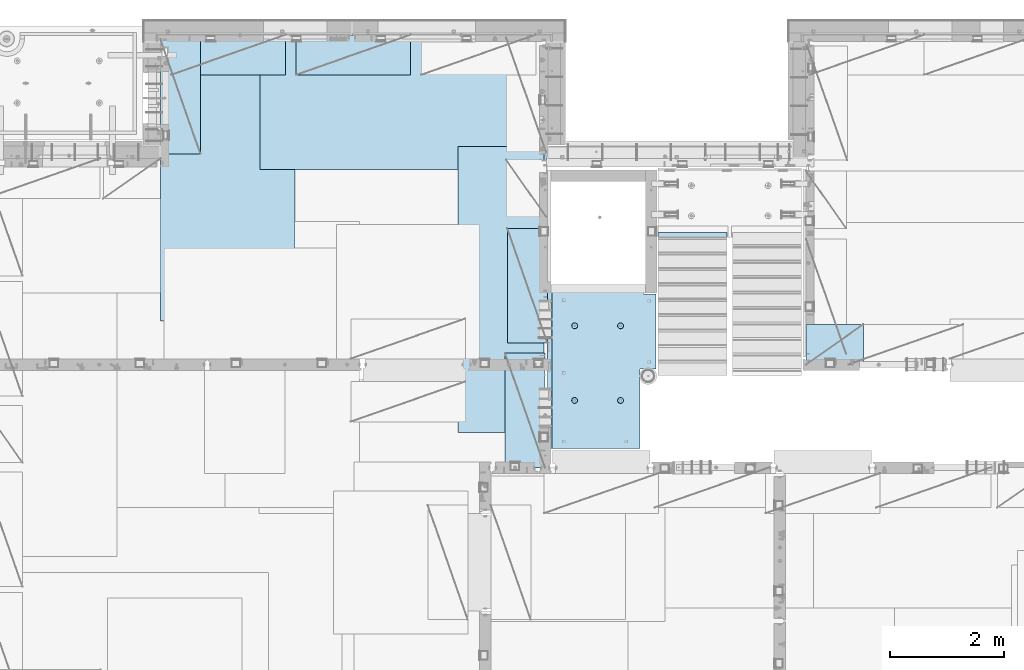
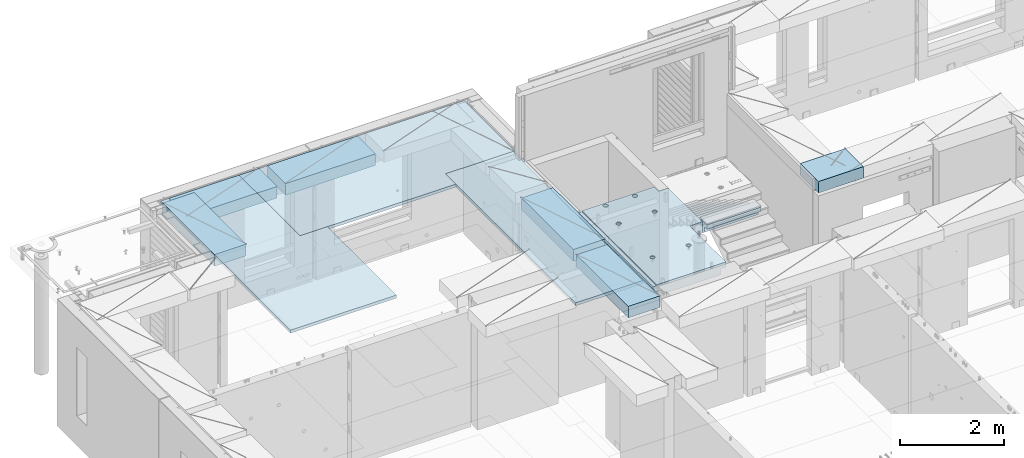
# One storey, part 200 of 341: 10 plates, 1 slab, 11 elements without a shape of their own.
"""IFC2X3 building model written with IfcOpenShell, lengths in millimetres."""

from ifc_helpers import new_model, si_unit, frame, origin_with_axes, place, context, subcontext, project, spatial, faceted_brep, material, type_object, element, aggregate, save


model = new_model("IFC2X3")

# Units and contexts
model_context = context("Model", 3, precision=1e-05, world=origin_with_axes())
body_context = subcontext(model_context, "Body", "Model", "MODEL_VIEW")
ifc_project = project(units=[si_unit("LENGTHUNIT", "METRE", prefix="MILLI"), si_unit("AREAUNIT", "SQUARE_METRE"), si_unit("VOLUMEUNIT", "CUBIC_METRE"), si_unit("MASSUNIT", "GRAM", prefix="KILO"), si_unit("TIMEUNIT", "SECOND"), si_unit("PLANEANGLEUNIT", "RADIAN"), si_unit("SOLIDANGLEUNIT", "STERADIAN"), si_unit("THERMODYNAMICTEMPERATUREUNIT", "DEGREE_CELSIUS"), si_unit("LUMINOUSINTENSITYUNIT", "LUMEN")], contexts=[model_context])

# Site, building, storey
site_placement = place(None, origin_with_axes())
site = spatial("IfcSite", under=ifc_project, at=site_placement, CompositionType="ELEMENT")
building_placement = place(site_placement, origin_with_axes())
building = spatial("IfcBuilding", under=site, at=building_placement, CompositionType="ELEMENT")
storey_placement = place(building_placement, origin_with_axes())
storey = spatial("IfcBuildingStorey", under=building, at=storey_placement, Name="5", CompositionType="ELEMENT", Elevation=0.0)

# Assembly, plate
assembly_1_placement = place(storey_placement, origin_with_axes())
assembly_1 = element("IfcElementAssembly", 1, at=assembly_1_placement, inside=storey, Name="E9", AssemblyPlace="NOTDEFINED", PredefinedType="NOTDEFINED")
ifc_material_1 = material(Name="Undefined/C32/40")
plate_type_1 = type_object("IfcPlateType", PredefinedType="NOTDEFINED")
plate_1_placement = place(assembly_1_placement, frame((20285.0002457424, 19199.9998138874, 95260.0), z_axis=(0.0, -1.0, 0.0), x_axis=(0.0, 0.0, -1.0)))
plate_1 = element("IfcPlate", 2, at=plate_1_placement, type_object=plate_type_1, material=ifc_material_1, Name="E9", context=body_context, shape_type="Brep", body=[
    faceted_brep([(0.0, -600.0, 0.0), (0.0, -600.0, 30.0), (0.0, 600.0, 30.0), (0.0, 600.0, 0.0), (-136.699996948242, -600.0, 30.0), (-136.699996948242, 600.0, 30.0), (-136.699996948242, -600.0, 300.0), (-136.699996948242, 600.0, 300.0), (-303.399993896484, -600.0, 300.0), (-303.399993896484, 600.0, 300.0), (-303.399993896484, -600.0, 570.0), (-303.399993896484, 600.0, 570.0), (-470.100006103516, -600.0, 570.0), (-470.100006103516, 600.0, 570.0), (-470.100006103516, -600.0, 840.0), (-470.100006103516, 600.0, 840.0), (-636.799987792969, -600.0, 840.0), (-636.799987792969, 600.0, 840.0), (-636.799987792969, -600.0, 1110.0), (-636.799987792969, 600.0, 1110.0), (-803.5, -600.0, 1110.0), (-803.5, 600.0, 1110.0), (-803.5, -600.0, 1380.0), (-803.5, 600.0, 1380.0), (-970.200012207031, -600.0, 1380.0), (-970.200012207031, 600.0, 1380.0), (-970.200012207031, -600.0, 1650.0), (-970.200012207031, 600.0, 1650.0), (-1136.90002441406, -600.0, 1650.0), (-1136.90002441406, 600.0, 1650.0), (-1136.90002441406, -600.0, 1920.0), (-1136.90002441406, 600.0, 1920.0), (-1303.59997558594, -600.0, 1920.0), (-1303.59997558594, 600.0, 1920.0), (-1303.59997558594, -600.0, 2190.0), (-1303.59997558594, 600.0, 2190.0), (-1470.30004882813, -600.0, 2190.0), (-1470.30004882813, 600.0, 2190.0), (-1470.30004882813, -600.0, 2410.0), (-1470.30004882813, 600.0, 2410.0), (-1370.30004882813, -600.0, 2410.0), (-1370.30004882813, 600.0, 2410.0), (-1370.30004882813, -600.0, 2310.0), (-1370.30004882813, 600.0, 2310.0), (-1236.65991210938, -600.0, 2310.0), (-1236.65991210938, 600.0, 2310.0), (170.0, -600.0, 31.6665592193604), (170.0, 600.0, 31.6665592193604), (170.0, -600.0, 20.0), (170.0, 600.0, 20.0), (135.0, -600.0, 20.0), (135.0, 600.0, 20.0), (135.0, -600.0, -90.0), (135.0, 600.0, -90.0), (25.0, -600.0, -90.0), (25.0, 600.0, -90.0), (25.0, -600.0, 0.0), (25.0, 600.0, 0.0)], [[[0, 1, 2, 3]], [[1, 4, 5, 2]], [[4, 6, 7, 5]], [[6, 8, 9, 7]], [[8, 10, 11, 9]], [[10, 12, 13, 11]], [[12, 14, 15, 13]], [[14, 16, 17, 15]], [[16, 18, 19, 17]], [[18, 20, 21, 19]], [[20, 22, 23, 21]], [[22, 24, 25, 23]], [[24, 26, 27, 25]], [[26, 28, 29, 27]], [[28, 30, 31, 29]], [[30, 32, 33, 31]], [[32, 34, 35, 33]], [[34, 36, 37, 35]], [[36, 38, 39, 37]], [[38, 40, 41, 39]], [[40, 42, 43, 41]], [[42, 44, 45, 43]], [[44, 46, 47, 45]], [[46, 48, 49, 47]], [[48, 50, 51, 49]], [[50, 52, 53, 51]], [[52, 54, 55, 53]], [[54, 56, 57, 55]], [[56, 0, 3, 57]], [[5, 7, 9, 11, 13, 15, 17, 19, 21, 23, 25, 27, 29, 31, 33, 35, 37, 39, 41, 43, 45, 47, 49, 51, 53, 55, 57, 3, 2]], [[56, 54, 52, 50, 48, 46, 44, 42, 40, 38, 36, 34, 32, 30, 28, 26, 24, 22, 20, 18, 16, 14, 12, 10, 8, 6, 4, 1, 0]]]),
])
aggregate(assembly_1, [plate_1])

# Assembly, slab
assembly_2_placement = place(storey_placement, origin_with_axes())
assembly_2 = element("IfcElementAssembly", 3, at=assembly_2_placement, inside=storey, AssemblyPlace="NOTDEFINED", PredefinedType="REINFORCEMENT_UNIT")
ifc_material_2 = material(Name="CONCRETE/C25/30")
slab_type = type_object("IfcSlabType", PredefinedType="NOTDEFINED")
slab_placement = place(assembly_2_placement, frame((19370.0122708302, 15509.9992031236, 96620.0), z_axis=(-0.999999999999509, -9.91000000794397e-07, 0.0), x_axis=(-1.19799915409591e-06, 0.999999999999282, 0.0)))
slab = element("IfcSlab", 4, at=slab_placement, type_object=slab_type, material=ifc_material_2, PredefinedType="FLOOR", context=body_context, shape_type="Brep", body=[
    faceted_brep([(0.00270234311210515, 30.0, 1600.01636881603), (700.003686840937, 30.0, 1600.01632471597), (700.003459213352, 30.0, 1410.0099940095), (0.0034592138545122, 30.0, 1410.0108326095), (700.003459213352, 130.0, 1410.0099940095), (700.003686840937, 50.0008724475629, 1600.01632471597), (700.003710793628, 50.0008724475629, 1620.01159965654), (700.003710793628, 130.0, 1620.01159965654), (0.00238143379829125, 130.0, 1410.01083261132), (2149.99368684227, 30.0, 1600.01623336659), (2149.99345921271, 30.0, 1410.00825692148), (1649.99345921307, 30.0, 1410.00885592148), (1649.99368684195, 30.0, 1600.01626486659), (1390.00354003907, -130.0, -1.24055077321827e-09), (0.0, -130.0, -3.63797880709171e-12), (0.0, -10.0, 0.0), (1390.00503210942, -10.0000000000582, -8.29459168016911e-10), (0.00020267313993827, -10.0000000000582, 119.999691808891), (1390.0049992294, -10.0000000000582, 120.000072670202), (1390.0049992294, 129.999999999942, 120.000072670202), (0.000202673141757259, 130.0, 119.999691808891), (1390.00354003907, 130.0, -1.24055077321827e-09), (1390.00305175782, -130.0, -279.993591308594), (1390.00350516116, 130.0, -19.9999273271205), (1390.00305175782, 130.0, -279.993591308594), (2704.99731446005, 130.0, -279.993808230734), (2704.99731446008, -130.0, -279.993645464809), (2704.99757802008, 130.0, -59.9936454649687), (2704.99757802008, -130.000000000015, -59.9936454649687), (2869.99708830242, -130.0, -59.9938431343799), (2869.99708830242, 130.0, -59.9938431343799), (2869.99538188219, 50.0011350165441, 1600.0161880065), (2869.99536132813, 50.0011350165441, 1620.01123046875), (2149.99371079323, 50.0010478963522, 1620.01135296499), (2149.99368684227, 50.0010478963377, 1600.0162333666), (2869.99536132813, -109.999999999985, 1620.01123046875), (0.00273611420016096, -109.999999999985, 1620.01171875), (0.0026009984267148, -109.999999999985, 1540.01171889739), (2869.99544356416, -109.999999999985, 1540.01180212718), (2869.99536132813, -49.9988649834559, 1620.01123046875), (0.00273611420016096, -49.9992122525582, 1620.01171875), (2869.99538188219, -49.9988649834559, 1600.01618800648), (0.00270234311210515, -49.9992122525582, 1600.01636881602), (2869.99544356416, -129.999999999985, 1540.01180212718), (2869.99536132813, 130.0, 1620.01123046875), (2149.99371079323, 130.0, 1620.01135296499), (2149.99345921271, 130.0, 1410.00825692148), (1649.99345921307, 130.0, 1410.00885592148), (1649.99371079351, 130.0, 1620.01143803163), (1649.99371079351, 50.0009873963572, 1620.01143803163), (1649.99368684195, 50.0009873963427, 1600.0162648666), (0.0026009984267148, -130.0, 1540.01171889739), (858.080152798024, -110.0, 1097.45747495204), (872.018574202059, -110.0, 1104.55943434983), (883.080174557956, -110.0, 1115.62100820216), (890.182167352177, -110.0, 1129.55941258986), (892.62936004754, -110.0, 1145.01025937688), (890.182204372413, -110.0, 1160.46111202734), (883.08024497463, -110.0, 1174.39953343137), (872.018671122296, -110.0, 1185.46113378727), (858.080266734594, -110.0, 1192.56312658148), (842.629419947572, -110.0, 1195.01031927685), (827.178567297122, -110.0, 1192.56316360172), (813.240145893089, -110.0, 1185.46120420394), (802.178545537192, -110.0, 1174.3996303516), (795.076552742968, -110.0, 1160.46122596391), (792.629360047609, -110.0, 1145.01037917688), (795.076515722732, -110.0, 1129.55952652643), (802.178475120518, -110.0, 1115.62110512239), (813.240048972852, -110.0, 1104.5595047665), (827.178453360551, -110.0, 1097.45751197228), (842.629300147573, -110.0, 1095.01031927692), (858.782461559409, -130.0, 1095.29598202818), (842.629297424846, -130.0, 1092.73759200419), (873.354447572716, -130.0, 1102.72075776224), (884.918847944788, -130.0, 1114.28513042604), (892.343658593298, -130.0, 1128.85709864954), (894.902087320264, -130.0, 1145.01025665415), (892.34369729627, -130.0, 1161.16342078871), (884.918921562221, -130.0, 1175.73540680203), (873.354548898418, -130.0, 1187.29980717409), (858.782580674915, -130.0, 1194.72461782261), (842.629422670299, -130.0, 1197.28304654957), (826.476258535738, -130.0, 1194.72465652558), (811.90427252243, -130.0, 1187.29988079152), (800.339872150354, -130.0, 1175.73550812773), (792.915061501848, -130.0, 1161.16353990422), (790.356632774883, -130.0, 1145.01038189961), (792.915022798874, -130.0, 1128.85721776505), (800.339798532925, -130.0, 1114.28523175174), (811.904171196727, -130.0, 1102.72083137967), (826.476139420232, -130.0, 1095.29602073116), (858.08015281103, -110.0, 296.158841760913), (872.018574215066, -110.0, 303.2608011587), (883.080174570961, -110.0, 314.322375011034), (890.182167365187, -110.0, 328.26077939873), (892.629360060546, -110.0, 343.711626185755), (890.182204385423, -110.0, 359.162478836206), (883.080244987636, -110.0, 373.100900240239), (872.018671135302, -110.0, 384.16250059614), (858.0802667476, -110.0, 391.264493390358), (842.62941996058, -110.0, 393.711686085717), (827.178567310128, -110.0, 391.264530410594), (813.240145906095, -110.0, 384.16257101281), (802.178545550198, -110.0, 373.100997160473), (795.076552755974, -110.0, 359.162592772776), (792.629360060615, -110.0, 343.711745985755), (795.076515735738, -110.0, 328.2608933353), (802.178475133525, -110.0, 314.322471931268), (813.240048985859, -110.0, 303.26087157537), (827.178453373557, -110.0, 296.158878781149), (842.629300160579, -110.0, 293.71168608579), (858.782461572417, -130.0, 293.997348837052), (842.629297437852, -130.0, 291.438958813062), (873.354447585723, -130.0, 301.422124571109), (884.918847957797, -130.0, 312.98649723491), (892.343658606304, -130.0, 327.558465458413), (894.90208733327, -130.0, 343.711623463027), (892.343697309276, -130.0, 359.864787597588), (884.918921575227, -130.0, 374.436773610898), (873.354548911424, -130.0, 386.001173982968), (858.782580687921, -130.0, 393.425984631478), (842.629422683307, -130.0, 395.984413358441), (826.476258548744, -130.0, 393.426023334454), (811.904272535436, -130.0, 386.001247600398), (800.339872163362, -130.0, 374.4368749366), (792.915061514856, -130.0, 359.864906713094), (790.356632787889, -130.0, 343.711748708483), (792.915022811882, -130.0, 327.558584573919), (800.339798545931, -130.0, 312.986598560612), (811.904171209735, -130.0, 301.422198188538), (826.47613943324, -130.0, 293.997387540028), (2162.44895919675, -110.0, 1097.45754446905), (2176.38738060079, -110.0, 1104.55950386684), (2187.44898095669, -110.0, 1115.62107771917), (2194.55097375091, -110.0, 1129.55948210687), (2196.99816644627, -110.0, 1145.0103288939), (2194.55101077115, -110.0, 1160.46118154435), (2187.44905137336, -110.0, 1174.39960294838), (2176.38747752102, -110.0, 1185.46120330428), (2162.44907313332, -110.0, 1192.5631960985), (2146.9982263463, -110.0, 1195.01038879386), (2131.54737369585, -110.0, 1192.56323311873), (2117.60895229182, -110.0, 1185.46127372095), (2106.54735193592, -110.0, 1174.39969986862), (2099.4453591417, -110.0, 1160.46129548092), (2096.99816644634, -110.0, 1145.01044869389), (2099.44532212146, -110.0, 1129.55959604344), (2106.54728151925, -110.0, 1115.62117463941), (2117.60885537159, -110.0, 1104.55957428351), (2131.54725975928, -110.0, 1097.45758148929), (2146.9981065463, -110.0, 1095.01038879393), (2163.15126795814, -130.0, 1095.2960515452), (2146.99810382357, -130.0, 1092.73766152121), (2177.72325397145, -130.0, 1102.72082727925), (2189.28765434352, -130.0, 1114.28519994305), (2196.71246499203, -130.0, 1128.85716816655), (2199.27089371899, -130.0, 1145.01032617117), (2196.71250369501, -130.0, 1161.16349030573), (2189.28772796095, -130.0, 1175.73547631904), (2177.72335529715, -130.0, 1187.29987669111), (2163.15138707365, -130.0, 1194.72468733962), (2146.99822906903, -130.0, 1197.28311606658), (2130.84506493447, -130.0, 1194.72472604259), (2116.27307892116, -130.0, 1187.29995030854), (2104.70867854909, -130.0, 1175.73557764474), (2097.28386790058, -130.0, 1161.16360942123), (2094.72543917361, -130.0, 1145.01045141662), (2097.2838291976, -130.0, 1128.85728728206), (2104.70860493166, -130.0, 1114.28530126875), (2116.27297759546, -130.0, 1102.72090089668), (2130.84494581896, -130.0, 1095.29609024817), (2162.44895913772, -110.0, 296.158911320326), (2176.38738054176, -110.0, 303.260870718113), (2187.44898089765, -110.0, 314.322444570447), (2194.55097369188, -110.0, 328.260848958147), (2196.99816638724, -110.0, 343.711695745169), (2194.55101071211, -110.0, 359.162548395623), (2187.44905131433, -110.0, 373.100969799652), (2176.38747746199, -110.0, 384.162570155553), (2162.44907307429, -110.0, 391.264562949771), (2146.99822628727, -110.0, 393.711755645134), (2131.54737363682, -110.0, 391.264599970007), (2117.60895223279, -110.0, 384.162640572227), (2106.54735187689, -110.0, 373.10106671989), (2099.44535908267, -110.0, 359.162662332194), (2096.99816638731, -110.0, 343.711815545168), (2099.44532206243, -110.0, 328.260962894718), (2106.54728146021, -110.0, 314.322541490685), (2117.60885531255, -110.0, 303.260941134788), (2131.54725970025, -110.0, 296.158948340562), (2146.99810648727, -110.0, 293.711755645207), (2163.15126789911, -130.0, 293.997418396466), (2146.99810376454, -130.0, 291.439028372479), (2177.72325391241, -130.0, 301.422194130522), (2189.28765428449, -130.0, 312.986566794323), (2196.712464933, -130.0, 327.558535017826), (2199.27089365996, -130.0, 343.711693022444), (2196.71250363597, -130.0, 359.864857157001), (2189.28772790192, -130.0, 374.436843170311), (2177.72335523811, -130.0, 386.001243542381), (2163.15138701461, -130.0, 393.426054190892), (2146.99822901, -130.0, 395.984482917858), (2130.84506487544, -130.0, 393.426092893867), (2116.27307886213, -130.0, 386.001317159811), (2104.70867849006, -130.0, 374.436944496014), (2097.28386784155, -130.0, 359.864976272507), (2094.72543911458, -130.0, 343.711818267897), (2097.28382913857, -130.0, 327.558654133332), (2104.70860487263, -130.0, 312.986668120026), (2116.27297753642, -130.0, 301.422267747952), (2130.84494575993, -130.0, 293.997457099442), (2805.44844412025, -130.0, 362.453408379821), (2805.44844412025, 130.0, 362.453408379821), (2789.9975914698, 130.0, 360.006252704694), (2789.9975914698, -130.0, 360.006252704694), (2819.38686552428, -130.0, 369.555367777604), (2819.38686552428, 130.0, 369.555367777604), (2830.44846588018, -130.0, 380.616941629942), (2830.44846588018, 130.0, 380.616941629942), (2837.5504586744, -130.0, 394.555346017638), (2837.5504586744, 130.0, 394.555346017638), (2839.99765136976, -130.0, 410.006192804663), (2839.99765136976, 130.0, 410.006192804663), (2837.55049569464, -130.0, 425.457045455114), (2837.55049569464, 130.0, 425.457045455114), (2830.44853629686, -130.0, 439.395466859147), (2830.44853629686, 130.0, 439.395466859147), (2819.38696244451, -130.0, 450.457067215044), (2819.38696244451, 130.0, 450.457067215044), (2805.44855805682, -130.0, 457.559060009266), (2805.44855805682, 130.0, 457.559060009266), (2789.9977112698, -130.0, 460.006252704625), (2789.9977112698, 130.0, 460.006252704625), (2774.54685861935, -130.0, 457.559097029502), (2774.54685861935, 130.0, 457.559097029502), (2760.60843721531, -130.0, 450.457137631718), (2760.60843721531, 130.0, 450.457137631718), (2749.54683685942, -130.0, 439.395563779381), (2749.54683685942, 130.0, 439.395563779381), (2742.44484406519, -130.0, 425.457159391684), (2742.44484406519, 130.0, 425.457159391684), (2739.99765136983, -130.0, 410.006312604663), (2739.99765136983, 130.0, 410.006312604663), (2742.44480704495, -130.0, 394.555459954208), (2742.44480704495, 130.0, 394.555459954208), (2749.54676644274, -130.0, 380.617038550175), (2749.54676644274, 130.0, 380.617038550175), (2760.60834029508, -130.0, 369.555438194278), (2760.60834029508, 130.0, 369.555438194278), (2774.54674468278, -130.0, 362.453445400057), (2774.54674468278, 130.0, 362.453445400057), (2760.60911899507, -130.0, 1019.55543819397), (2749.54754514274, -130.0, 1030.61703854987), (2742.44558574495, -130.0, 1044.5554599539), (2739.99843006983, -130.0, 1060.00631260435), (2742.44562276519, -130.0, 1075.45715939137), (2749.54761555942, -130.0, 1089.39556377907), (2760.60921591531, -130.0, 1100.45713763141), (2774.54763731935, -130.0, 1107.55909702919), (2789.9984899698, -130.0, 1110.00625270432), (2805.44933675682, -130.0, 1107.55906000896), (2819.38774114452, -130.0, 1100.45706721473), (2830.44931499685, -130.0, 1089.39546685884), (2837.55127439463, -130.0, 1075.4570454548), (2839.99843006976, -130.0, 1060.00619280435), (2837.5512373744, -130.0, 1044.55534601733), (2830.44924458018, -130.0, 1030.61694162963), (2819.38764422428, -130.0, 1019.55536777729), (2805.44922282025, -130.0, 1012.45340837951), (2789.9983701698, -130.0, 1010.00625270438), (2774.54752338277, -130.0, 1012.45344539975), (2819.38764422428, 130.0, 1019.55536777729), (2805.44922282025, 130.0, 1012.45340837951), (2830.44924458018, 130.0, 1030.61694162963), (2837.5512373744, 130.0, 1044.55534601733), (2839.99843006976, 130.0, 1060.00619280435), (2837.55127439463, 130.0, 1075.4570454548), (2830.44931499685, 130.0, 1089.39546685884), (2819.38774114452, 130.0, 1100.45706721473), (2805.44933675682, 130.0, 1107.55906000896), (2789.9984899698, 130.0, 1110.00625270432), (2774.54763731935, 130.0, 1107.55909702919), (2760.60921591531, 130.0, 1100.45713763141), (2749.54761555942, 130.0, 1089.39556377907), (2742.44562276519, 130.0, 1075.45715939137), (2739.99843006983, 130.0, 1060.00631260435), (2742.44558574495, 130.0, 1044.5554599539), (2749.54754514274, 130.0, 1030.61703854987), (2760.60911899507, 130.0, 1019.55543819397), (2774.54752338277, 130.0, 1012.45344539975), (2789.9983701698, 130.0, 1010.00625270438)], [[[0, 1, 2, 3]], [[4, 2, 1, 5, 6, 7]], [[8, 3, 2, 4]], [[9, 10, 11, 12]], [[13, 14, 15, 16]], [[15, 17, 18, 16]], [[19, 18, 17, 20]], [[16, 18, 19, 21]], [[22, 13, 16, 21, 23, 24]], [[22, 24, 25, 26]], [[26, 25, 27, 28]], [[29, 28, 27, 30]], [[31, 32, 33, 34]], [[35, 36, 37, 38]], [[36, 35, 39, 40]], [[41, 42, 40, 39]], [[35, 38, 43, 29, 30, 44, 32, 31, 41, 39]], [[32, 44, 45, 33]], [[46, 10, 9, 34, 33, 45]], [[47, 11, 10, 46]], [[48, 49, 50, 12, 11, 47]], [[49, 48, 7, 6]], [[50, 49, 6, 5]], [[42, 41, 31, 34, 9, 12, 50, 5, 1, 0]], [[20, 17, 15, 14, 51, 37, 36, 40, 42, 0, 3, 8]], [[43, 38, 37, 51]], [[52, 53, 54, 55, 56, 57, 58, 59, 60, 61, 62, 63, 64, 65, 66, 67, 68, 69, 70, 71]], [[72, 52, 71, 73]], [[74, 53, 52, 72]], [[75, 54, 53, 74]], [[76, 55, 54, 75]], [[77, 56, 55, 76]], [[78, 57, 56, 77]], [[79, 58, 57, 78]], [[80, 59, 58, 79]], [[81, 60, 59, 80]], [[82, 61, 60, 81]], [[83, 62, 61, 82]], [[84, 63, 62, 83]], [[85, 64, 63, 84]], [[86, 65, 64, 85]], [[87, 66, 65, 86]], [[88, 67, 66, 87]], [[89, 68, 67, 88]], [[90, 69, 68, 89]], [[91, 70, 69, 90]], [[73, 71, 70, 91]], [[92, 93, 94, 95, 96, 97, 98, 99, 100, 101, 102, 103, 104, 105, 106, 107, 108, 109, 110, 111]], [[112, 92, 111, 113]], [[114, 93, 92, 112]], [[115, 94, 93, 114]], [[116, 95, 94, 115]], [[117, 96, 95, 116]], [[118, 97, 96, 117]], [[119, 98, 97, 118]], [[120, 99, 98, 119]], [[121, 100, 99, 120]], [[122, 101, 100, 121]], [[123, 102, 101, 122]], [[124, 103, 102, 123]], [[125, 104, 103, 124]], [[126, 105, 104, 125]], [[127, 106, 105, 126]], [[128, 107, 106, 127]], [[129, 108, 107, 128]], [[130, 109, 108, 129]], [[131, 110, 109, 130]], [[113, 111, 110, 131]], [[132, 133, 134, 135, 136, 137, 138, 139, 140, 141, 142, 143, 144, 145, 146, 147, 148, 149, 150, 151]], [[152, 132, 151, 153]], [[154, 133, 132, 152]], [[155, 134, 133, 154]], [[156, 135, 134, 155]], [[157, 136, 135, 156]], [[158, 137, 136, 157]], [[159, 138, 137, 158]], [[160, 139, 138, 159]], [[161, 140, 139, 160]], [[162, 141, 140, 161]], [[163, 142, 141, 162]], [[164, 143, 142, 163]], [[165, 144, 143, 164]], [[166, 145, 144, 165]], [[167, 146, 145, 166]], [[168, 147, 146, 167]], [[169, 148, 147, 168]], [[170, 149, 148, 169]], [[171, 150, 149, 170]], [[153, 151, 150, 171]], [[172, 173, 174, 175, 176, 177, 178, 179, 180, 181, 182, 183, 184, 185, 186, 187, 188, 189, 190, 191]], [[192, 172, 191, 193]], [[194, 173, 172, 192]], [[195, 174, 173, 194]], [[196, 175, 174, 195]], [[197, 176, 175, 196]], [[198, 177, 176, 197]], [[199, 178, 177, 198]], [[200, 179, 178, 199]], [[201, 180, 179, 200]], [[202, 181, 180, 201]], [[203, 182, 181, 202]], [[204, 183, 182, 203]], [[205, 184, 183, 204]], [[206, 185, 184, 205]], [[207, 186, 185, 206]], [[208, 187, 186, 207]], [[209, 188, 187, 208]], [[210, 189, 188, 209]], [[211, 190, 189, 210]], [[193, 191, 190, 211]], [[212, 213, 214, 215]], [[216, 217, 213, 212]], [[218, 219, 217, 216]], [[220, 221, 219, 218]], [[222, 223, 221, 220]], [[224, 225, 223, 222]], [[226, 227, 225, 224]], [[228, 229, 227, 226]], [[230, 231, 229, 228]], [[232, 233, 231, 230]], [[234, 235, 233, 232]], [[236, 237, 235, 234]], [[238, 239, 237, 236]], [[240, 241, 239, 238]], [[242, 243, 241, 240]], [[244, 245, 243, 242]], [[246, 247, 245, 244]], [[248, 249, 247, 246]], [[250, 251, 249, 248]], [[215, 214, 251, 250]], [[14, 13, 22, 26, 28, 29, 43, 51], [252, 253, 254, 255, 256, 257, 258, 259, 260, 261, 262, 263, 264, 265, 266, 267, 268, 269, 270, 271], [248, 246, 244, 242, 240, 238, 236, 234, 232, 230, 228, 226, 224, 222, 220, 218, 216, 212, 215, 250], [210, 209, 208, 207, 206, 205, 204, 203, 202, 201, 200, 199, 198, 197, 196, 195, 194, 192, 193, 211], [170, 169, 168, 167, 166, 165, 164, 163, 162, 161, 160, 159, 158, 157, 156, 155, 154, 152, 153, 171], [130, 129, 128, 127, 126, 125, 124, 123, 122, 121, 120, 119, 118, 117, 116, 115, 114, 112, 113, 131], [90, 89, 88, 87, 86, 85, 84, 83, 82, 81, 80, 79, 78, 77, 76, 75, 74, 72, 73, 91]], [[268, 272, 273, 269]], [[267, 274, 272, 268]], [[266, 275, 274, 267]], [[265, 276, 275, 266]], [[264, 277, 276, 265]], [[263, 278, 277, 264]], [[262, 279, 278, 263]], [[261, 280, 279, 262]], [[260, 281, 280, 261]], [[259, 282, 281, 260]], [[258, 283, 282, 259]], [[257, 284, 283, 258]], [[256, 285, 284, 257]], [[255, 286, 285, 256]], [[254, 287, 286, 255]], [[253, 288, 287, 254]], [[252, 289, 288, 253]], [[271, 290, 289, 252]], [[270, 291, 290, 271]], [[269, 273, 291, 270]], [[48, 47, 46, 45, 44, 30, 27, 25, 24, 23, 21, 19, 20, 8, 4, 7], [272, 274, 275, 276, 277, 278, 279, 280, 281, 282, 283, 284, 285, 286, 287, 288, 289, 290, 291, 273], [217, 219, 221, 223, 225, 227, 229, 231, 233, 235, 237, 239, 241, 243, 245, 247, 249, 251, 214, 213]]]),
])
aggregate(assembly_2, [slab])

# Assembly, plate
assembly_3_placement = place(storey_placement, origin_with_axes())
assembly_3 = element("IfcElementAssembly", 5, at=assembly_3_placement, inside=storey, Name="Steel Assembly", AssemblyPlace="NOTDEFINED", PredefinedType="NOTDEFINED")
ifc_material_3 = material()
plate_type_2 = type_object("IfcPlateType", PredefinedType="NOTDEFINED")
plate_2_placement = place(assembly_3_placement, frame((12729.9998779297, 22740.0009765625, 96695.1), z_axis=(1.0, 0.0, 0.0), x_axis=(0.0, -1.0, 0.0)))
plate_2 = element("IfcPlate", 6, at=plate_2_placement, type_object=plate_type_2, material=ifc_material_3, context=body_context, shape_type="Brep", body=[
    faceted_brep([(0.0, -35.0, 0.0), (0.0, -35.0, 5000.0), (0.0, 35.0, 5000.0), (0.0, 35.0, 0.0), (2349.99951171875, -35.0, 5000.0), (2349.99951171875, 35.0, 5000.0), (2350.0, -35.0, 0.0), (2350.0, 35.0, 0.0)], [[[0, 1, 2, 3]], [[1, 4, 5, 2]], [[4, 6, 7, 5]], [[6, 0, 3, 7]], [[5, 7, 3, 2]], [[6, 4, 1, 0]]]),
])
aggregate(assembly_3, [plate_2])

assembly_4_placement = place(storey_placement, origin_with_axes())
assembly_4 = element("IfcElementAssembly", 7, at=assembly_4_placement, inside=storey, Name="Steel Assembly", AssemblyPlace="NOTDEFINED", PredefinedType="NOTDEFINED")
plate_3_placement = place(assembly_4_placement, frame((13340.0, 22740.0, 96695.1), z_axis=(0.0, -1.0, 0.0), x_axis=(-1.0, 3.00000001838171e-08, 0.0)))
plate_3 = element("IfcPlate", 8, at=plate_3_placement, type_object=plate_type_2, material=ifc_material_3, context=body_context, shape_type="Brep", body=[
    faceted_brep([(0.0, -35.0, 0.0), (0.0, -35.0, 5000.0), (0.0, 35.0, 5000.0), (0.0, 35.0, 0.0), (2349.99951171875, -35.0, 5000.0), (2349.99951171875, 35.0, 5000.0), (2350.0, -35.0, 0.0), (2350.0, 35.0, 0.0)], [[[0, 1, 2, 3]], [[1, 4, 5, 2]], [[4, 6, 7, 5]], [[6, 0, 3, 7]], [[5, 7, 3, 2]], [[6, 4, 1, 0]]]),
])
aggregate(assembly_4, [plate_3])

assembly_5_placement = place(storey_placement, origin_with_axes())
assembly_5 = element("IfcElementAssembly", 9, at=assembly_5_placement, inside=storey, Name="Steel Assembly", AssemblyPlace="NOTDEFINED", PredefinedType="NOTDEFINED")
plate_type_3 = type_object("IfcPlateType", PredefinedType="NOTDEFINED")
plate_4_placement = place(assembly_5_placement, frame((17690.0000122641, 20790.0, 96695.1000003815), z_axis=(0.0, -1.0, 0.0), x_axis=(-1.0, 3.00000001838171e-08, 0.0)))
plate_4 = element("IfcPlate", 10, at=plate_4_placement, type_object=plate_type_3, material=ifc_material_3, context=body_context, shape_type="Brep", body=[
    faceted_brep([(0.0, -35.0, 0.0), (0.0, -35.0, 5000.0), (0.0, 35.0, 5000.0), (0.0, 35.0, 0.0), (1499.99951171875, -35.0, 5000.0), (1499.99951171875, 35.0, 5000.0), (1500.0, -35.0, 0.0), (1500.0, 35.0, 0.0)], [[[0, 1, 2, 3]], [[1, 4, 5, 2]], [[4, 6, 7, 5]], [[6, 0, 3, 7]], [[5, 7, 3, 2]], [[6, 4, 1, 0]]]),
])
aggregate(assembly_5, [plate_4])

assembly_6_placement = place(storey_placement, origin_with_axes())
assembly_6 = element("IfcElementAssembly", 11, at=assembly_6_placement, inside=storey, Name="Steel Assembly", AssemblyPlace="NOTDEFINED", PredefinedType="NOTDEFINED")
plate_type_4 = type_object("IfcPlateType", PredefinedType="NOTDEFINED")
plate_5_placement = place(assembly_6_placement, frame((22270.0, 16979.9999999293, 96595.3), z_axis=(0.0, 1.0, 0.0), x_axis=(1.0, 0.0, 0.0)))
plate_5 = element("IfcPlate", 12, at=plate_5_placement, type_object=plate_type_4, material=ifc_material_3, Name="RE1_1/2", context=body_context, shape_type="Brep", body=[
    faceted_brep([(1.81898940354586e-12, -135.0, 1.81898940354586e-12), (0.0, -135.0, 699.999999999996), (0.0, 135.0, 699.999999999996), (1.81898940354586e-12, 135.0, 1.81898940354586e-12), (999.99951171875, -135.0, 700.0), (999.99951171875, 135.0, 700.0), (1000.0, -135.0, 0.0), (1000.0, 135.0, 0.0)], [[[0, 1, 2, 3]], [[1, 4, 5, 2]], [[4, 6, 7, 5]], [[6, 0, 3, 7]], [[5, 7, 3, 2]], [[6, 4, 1, 0]]]),
])
aggregate(assembly_6, [plate_5])

assembly_7_placement = place(storey_placement, origin_with_axes())
assembly_7 = element("IfcElementAssembly", 13, at=assembly_7_placement, inside=storey, Name="Steel Assembly", AssemblyPlace="NOTDEFINED", PredefinedType="NOTDEFINED")
plate_6_placement = place(assembly_7_placement, frame((17750.0001220703, 17360.0, 96595.3), z_axis=(-1.0, 3.00000001838171e-08, 0.0), x_axis=(0.0, 1.0, 0.0)))
plate_6 = element("IfcPlate", 14, at=plate_6_placement, type_object=plate_type_4, material=ifc_material_3, Name="RE1", context=body_context, shape_type="Brep", body=[
    faceted_brep([(1.81898940354586e-12, -135.0, 1.81898940354586e-12), (0.0, -135.0, 699.999999999996), (0.0, 135.0, 699.999999999996), (1.81898940354586e-12, 135.0, 1.81898940354586e-12), (1999.99951171875, -135.0, 699.999999999993), (1999.99951171875, 135.0, 699.999999999993), (2000.0, -135.0, -3.63797880709171e-12), (2000.0, 135.0, -3.63797880709171e-12)], [[[0, 1, 2, 3]], [[1, 4, 5, 2]], [[4, 6, 7, 5]], [[6, 0, 3, 7]], [[5, 7, 3, 2]], [[6, 4, 1, 0]]]),
])
aggregate(assembly_7, [plate_6])

assembly_8_placement = place(storey_placement, origin_with_axes())
assembly_8 = element("IfcElementAssembly", 15, at=assembly_8_placement, inside=storey, Name="Steel Assembly", AssemblyPlace="NOTDEFINED", PredefinedType="NOTDEFINED")
plate_7_placement = place(assembly_8_placement, frame((17710.0001220703, 15180.0, 96595.3), z_axis=(-1.0, 3.00000001838171e-08, 0.0), x_axis=(0.0, 1.0, 0.0)))
plate_7 = element("IfcPlate", 16, at=plate_7_placement, type_object=plate_type_4, material=ifc_material_3, Name="RE1", context=body_context, shape_type="Brep", body=[
    faceted_brep([(1.81898940354586e-12, -135.0, 1.81898940354586e-12), (0.0, -135.0, 699.999999999996), (0.0, 135.0, 699.999999999996), (1.81898940354586e-12, 135.0, 1.81898940354586e-12), (1999.99951171875, -135.0, 699.999999999993), (1999.99951171875, 135.0, 699.999999999993), (2000.0, -135.0, -3.63797880709171e-12), (2000.0, 135.0, -3.63797880709171e-12)], [[[0, 1, 2, 3]], [[1, 4, 5, 2]], [[4, 6, 7, 5]], [[6, 0, 3, 7]], [[5, 7, 3, 2]], [[6, 4, 1, 0]]]),
])
aggregate(assembly_8, [plate_7])

assembly_9_placement = place(storey_placement, origin_with_axes())
assembly_9 = element("IfcElementAssembly", 17, at=assembly_9_placement, inside=storey, Name="Steel Assembly", AssemblyPlace="NOTDEFINED", PredefinedType="NOTDEFINED")
plate_8_placement = place(assembly_9_placement, frame((13175.0, 22740.0001220703, 96595.3), z_axis=(0.0, -1.0, 0.0), x_axis=(-1.0, 3.00000001838171e-08, 0.0)))
plate_8 = element("IfcPlate", 18, at=plate_8_placement, type_object=plate_type_4, material=ifc_material_3, Name="RE1", context=body_context, shape_type="Brep", body=[
    faceted_brep([(1.81898940354586e-12, -135.0, 1.81898940354586e-12), (0.0, -135.0, 699.999999999996), (0.0, 135.0, 699.999999999996), (1.81898940354586e-12, 135.0, 1.81898940354586e-12), (1999.99951171875, -135.0, 699.999999999993), (1999.99951171875, 135.0, 699.999999999993), (2000.0, -135.0, -3.63797880709171e-12), (2000.0, 135.0, -3.63797880709171e-12)], [[[0, 1, 2, 3]], [[1, 4, 5, 2]], [[4, 6, 7, 5]], [[6, 0, 3, 7]], [[5, 7, 3, 2]], [[6, 4, 1, 0]]]),
])
aggregate(assembly_9, [plate_8])

assembly_10_placement = place(storey_placement, origin_with_axes())
assembly_10 = element("IfcElementAssembly", 19, at=assembly_10_placement, inside=storey, Name="Steel Assembly", AssemblyPlace="NOTDEFINED", PredefinedType="NOTDEFINED")
plate_9_placement = place(assembly_10_placement, frame((15360.0, 22740.0001220703, 96595.3), z_axis=(0.0, -1.0, 0.0), x_axis=(-1.0, 3.00000001838171e-08, 0.0)))
plate_9 = element("IfcPlate", 20, at=plate_9_placement, type_object=plate_type_4, material=ifc_material_3, Name="RE1", context=body_context, shape_type="Brep", body=[
    faceted_brep([(1.81898940354586e-12, -135.0, 1.81898940354586e-12), (0.0, -135.0, 699.999999999996), (0.0, 135.0, 699.999999999996), (1.81898940354586e-12, 135.0, 1.81898940354586e-12), (1999.99951171875, -135.0, 699.999999999993), (1999.99951171875, 135.0, 699.999999999993), (2000.0, -135.0, -3.63797880709171e-12), (2000.0, 135.0, -3.63797880709171e-12)], [[[0, 1, 2, 3]], [[1, 4, 5, 2]], [[4, 6, 7, 5]], [[6, 0, 3, 7]], [[5, 7, 3, 2]], [[6, 4, 1, 0]]]),
])
aggregate(assembly_10, [plate_9])

assembly_11_placement = place(storey_placement, origin_with_axes())
assembly_11 = element("IfcElementAssembly", 21, at=assembly_11_placement, inside=storey, Name="Steel Assembly", AssemblyPlace="NOTDEFINED", PredefinedType="NOTDEFINED")
plate_10_placement = place(assembly_11_placement, frame((10989.9998779297, 22660.0, 96595.3), z_axis=(1.0, 0.0, 0.0), x_axis=(0.0, -1.0, 0.0)))
plate_10 = element("IfcPlate", 22, at=plate_10_placement, type_object=plate_type_4, material=ifc_material_3, Name="RE1", context=body_context, shape_type="Brep", body=[
    faceted_brep([(1.81898940354586e-12, -135.0, 1.81898940354586e-12), (0.0, -135.0, 699.999999999996), (0.0, 135.0, 699.999999999996), (1.81898940354586e-12, 135.0, 1.81898940354586e-12), (1999.99951171875, -135.0, 699.999999999993), (1999.99951171875, 135.0, 699.999999999993), (2000.0, -135.0, -3.63797880709171e-12), (2000.0, 135.0, -3.63797880709171e-12)], [[[0, 1, 2, 3]], [[1, 4, 5, 2]], [[4, 6, 7, 5]], [[6, 0, 3, 7]], [[5, 7, 3, 2]], [[6, 4, 1, 0]]]),
])
aggregate(assembly_11, [plate_10])

save(model, "model.ifc")
